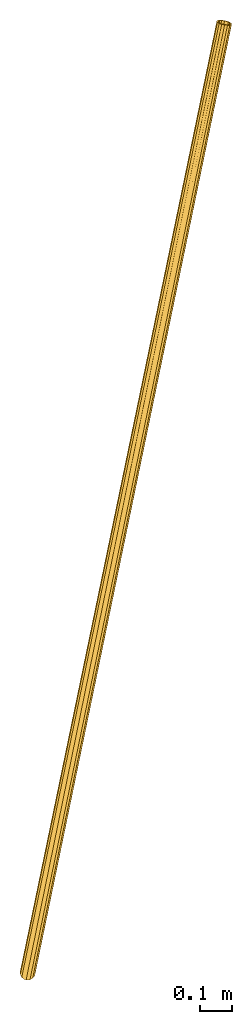
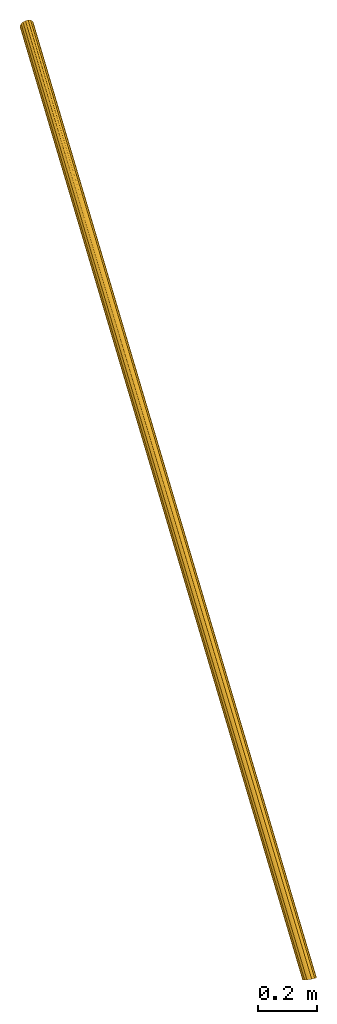
# One storey: 1 railing.
"""IFC4 building model written with IfcOpenShell, lengths in feet."""

from ifc_helpers import new_model, entity, si_unit, converted_unit, derived_unit, direction, frame, origin_with_axes, place, context, subcontext, project, spatial, polygons, material, type_object, element, save


model = new_model("IFC4")

# Units and contexts
model_context = context("Model", 3, precision=1e-05, world=origin_with_axes(), true_north=direction((0.0, 1.0)))
body_context = subcontext(model_context, "Body", "Model", "MODEL_VIEW", scale=1.0)
ifc_project = project(units=[converted_unit("LENGTHUNIT", "foot", entity("IfcReal", 30.48), si_unit("LENGTHUNIT", "METRE", prefix="CENTI"), dimensions=[1, 0, 0, 0, 0, 0, 0]), si_unit("AREAUNIT", "SQUARE_METRE"), si_unit("VOLUMEUNIT", "CUBIC_METRE"), si_unit("ABSORBEDDOSEUNIT", "GRAY"), si_unit("AMOUNTOFSUBSTANCEUNIT", "MOLE"), si_unit("DOSEEQUIVALENTUNIT", "SIEVERT"), si_unit("ELECTRICCAPACITANCEUNIT", "FARAD"), si_unit("ELECTRICCHARGEUNIT", "COULOMB"), si_unit("ELECTRICCONDUCTANCEUNIT", "SIEMENS"), si_unit("ELECTRICCURRENTUNIT", "AMPERE"), si_unit("ELECTRICRESISTANCEUNIT", "OHM"), si_unit("ELECTRICVOLTAGEUNIT", "VOLT"), si_unit("ENERGYUNIT", "JOULE"), si_unit("FORCEUNIT", "NEWTON"), si_unit("FREQUENCYUNIT", "HERTZ"), si_unit("ILLUMINANCEUNIT", "LUX"), si_unit("INDUCTANCEUNIT", "HENRY"), si_unit("LUMINOUSFLUXUNIT", "LUMEN"), si_unit("LUMINOUSINTENSITYUNIT", "CANDELA"), si_unit("MAGNETICFLUXDENSITYUNIT", "TESLA"), si_unit("MAGNETICFLUXUNIT", "WEBER"), si_unit("MASSUNIT", "GRAM"), converted_unit("PLANEANGLEUNIT", "degree", entity("IfcReal", 0.0174532925199433), si_unit("PLANEANGLEUNIT", "RADIAN"), dimensions=[0, 0, 0, 0, 0, 0, 0]), si_unit("POWERUNIT", "WATT"), si_unit("PRESSUREUNIT", "PASCAL"), si_unit("RADIOACTIVITYUNIT", "BECQUEREL"), si_unit("SOLIDANGLEUNIT", "STERADIAN"), si_unit("THERMODYNAMICTEMPERATUREUNIT", "KELVIN"), si_unit("TIMEUNIT", "SECOND"), derived_unit("ACCELERATIONUNIT", [(converted_unit("LENGTHUNIT", "foot", entity("IfcReal", 30.48), si_unit("LENGTHUNIT", "METRE", prefix="CENTI"), dimensions=[1, 0, 0, 0, 0, 0, 0]), 1), (si_unit("TIMEUNIT", "SECOND"), -2)]), derived_unit("ANGULARVELOCITYUNIT", [(converted_unit("PLANEANGLEUNIT", "degree", entity("IfcReal", 0.0174532925199433), si_unit("PLANEANGLEUNIT", "RADIAN"), dimensions=[0, 0, 0, 0, 0, 0, 0]), 1), (si_unit("TIMEUNIT", "SECOND"), -1)]), derived_unit("CURVATUREUNIT", [(converted_unit("PLANEANGLEUNIT", "degree", entity("IfcReal", 0.0174532925199433), si_unit("PLANEANGLEUNIT", "RADIAN"), dimensions=[0, 0, 0, 0, 0, 0, 0]), 1), (converted_unit("LENGTHUNIT", "foot", entity("IfcReal", 30.48), si_unit("LENGTHUNIT", "METRE", prefix="CENTI"), dimensions=[1, 0, 0, 0, 0, 0, 0]), -1)]), derived_unit("DYNAMICVISCOSITYUNIT", [(si_unit("PRESSUREUNIT", "PASCAL"), 1), (si_unit("TIMEUNIT", "SECOND"), 1)]), derived_unit("HEATFLUXDENSITYUNIT", [(si_unit("POWERUNIT", "WATT"), 1), (converted_unit("LENGTHUNIT", "foot", entity("IfcReal", 30.48), si_unit("LENGTHUNIT", "METRE", prefix="CENTI"), dimensions=[1, 0, 0, 0, 0, 0, 0]), -2)]), derived_unit("HEATINGVALUEUNIT", [(si_unit("ENERGYUNIT", "JOULE"), 1), (si_unit("MASSUNIT", "GRAM"), -1)]), derived_unit("INTEGERCOUNTRATEUNIT", [(si_unit("TIMEUNIT", "SECOND"), -1)]), derived_unit("IONCONCENTRATIONUNIT", [(si_unit("MASSUNIT", "GRAM"), 1), (si_unit("VOLUMEUNIT", "CUBIC_METRE"), -1)]), derived_unit("ISOTHERMALMOISTURECAPACITYUNIT", [(si_unit("VOLUMEUNIT", "CUBIC_METRE"), 1), (si_unit("MASSUNIT", "GRAM"), -1)]), derived_unit("KINEMATICVISCOSITYUNIT", [(si_unit("AREAUNIT", "SQUARE_METRE"), 1), (si_unit("TIMEUNIT", "SECOND"), -1)]), derived_unit("LINEARFORCEUNIT", [(si_unit("FORCEUNIT", "NEWTON"), 1), (converted_unit("LENGTHUNIT", "foot", entity("IfcReal", 30.48), si_unit("LENGTHUNIT", "METRE", prefix="CENTI"), dimensions=[1, 0, 0, 0, 0, 0, 0]), -1)]), derived_unit("LINEARMOMENTUNIT", [(si_unit("FORCEUNIT", "NEWTON"), 1), (converted_unit("LENGTHUNIT", "foot", entity("IfcReal", 30.48), si_unit("LENGTHUNIT", "METRE", prefix="CENTI"), dimensions=[1, 0, 0, 0, 0, 0, 0]), -1)]), derived_unit("LINEARSTIFFNESSUNIT", [(si_unit("FORCEUNIT", "NEWTON"), 1), (converted_unit("LENGTHUNIT", "foot", entity("IfcReal", 30.48), si_unit("LENGTHUNIT", "METRE", prefix="CENTI"), dimensions=[1, 0, 0, 0, 0, 0, 0]), -1)]), derived_unit("LINEARVELOCITYUNIT", [(converted_unit("LENGTHUNIT", "foot", entity("IfcReal", 30.48), si_unit("LENGTHUNIT", "METRE", prefix="CENTI"), dimensions=[1, 0, 0, 0, 0, 0, 0]), 1), (si_unit("TIMEUNIT", "SECOND"), -1)]), derived_unit("LUMINOUSINTENSITYDISTRIBUTIONUNIT", [(si_unit("LUMINOUSINTENSITYUNIT", "CANDELA"), 1), (si_unit("LUMINOUSFLUXUNIT", "LUMEN"), -1)]), derived_unit("MASSDENSITYUNIT", [(si_unit("MASSUNIT", "GRAM"), 1), (si_unit("VOLUMEUNIT", "CUBIC_METRE"), -1)]), derived_unit("MASSFLOWRATEUNIT", [(si_unit("MASSUNIT", "GRAM"), 1), (si_unit("TIMEUNIT", "SECOND"), -1)]), derived_unit("MASSPERLENGTHUNIT", [(si_unit("MASSUNIT", "GRAM"), 1), (converted_unit("LENGTHUNIT", "foot", entity("IfcReal", 30.48), si_unit("LENGTHUNIT", "METRE", prefix="CENTI"), dimensions=[1, 0, 0, 0, 0, 0, 0]), -1)]), derived_unit("MODULUSOFELASTICITYUNIT", [(si_unit("FORCEUNIT", "NEWTON"), 1), (si_unit("AREAUNIT", "SQUARE_METRE"), -1)]), derived_unit("MODULUSOFLINEARSUBGRADEREACTIONUNIT", [(si_unit("FORCEUNIT", "NEWTON"), 1), (converted_unit("LENGTHUNIT", "foot", entity("IfcReal", 30.48), si_unit("LENGTHUNIT", "METRE", prefix="CENTI"), dimensions=[1, 0, 0, 0, 0, 0, 0]), -2)]), derived_unit("MODULUSOFROTATIONALSUBGRADEREACTIONUNIT", [(si_unit("FORCEUNIT", "NEWTON"), 1), (converted_unit("LENGTHUNIT", "foot", entity("IfcReal", 30.48), si_unit("LENGTHUNIT", "METRE", prefix="CENTI"), dimensions=[1, 0, 0, 0, 0, 0, 0]), 1)]), derived_unit("MODULUSOFSUBGRADEREACTIONUNIT", [(si_unit("FORCEUNIT", "NEWTON"), 1), (si_unit("VOLUMEUNIT", "CUBIC_METRE"), -1)]), derived_unit("MOISTUREDIFFUSIVITYUNIT", [(si_unit("VOLUMEUNIT", "CUBIC_METRE"), 1), (si_unit("TIMEUNIT", "SECOND"), -1)]), derived_unit("MOLECULARWEIGHTUNIT", [(si_unit("MASSUNIT", "GRAM"), 1), (si_unit("AMOUNTOFSUBSTANCEUNIT", "MOLE"), -1)]), derived_unit("PLANARFORCEUNIT", [(si_unit("FORCEUNIT", "NEWTON"), 1), (converted_unit("LENGTHUNIT", "foot", entity("IfcReal", 30.48), si_unit("LENGTHUNIT", "METRE", prefix="CENTI"), dimensions=[1, 0, 0, 0, 0, 0, 0]), -2)]), derived_unit("ROTATIONALFREQUENCYUNIT", [(si_unit("TIMEUNIT", "SECOND"), -1)]), derived_unit("ROTATIONALMASSUNIT", [(si_unit("MASSUNIT", "GRAM"), 1), (converted_unit("LENGTHUNIT", "foot", entity("IfcReal", 30.48), si_unit("LENGTHUNIT", "METRE", prefix="CENTI"), dimensions=[1, 0, 0, 0, 0, 0, 0]), 2)]), derived_unit("ROTATIONALSTIFFNESSUNIT", [(si_unit("FORCEUNIT", "NEWTON"), 1), (converted_unit("LENGTHUNIT", "foot", entity("IfcReal", 30.48), si_unit("LENGTHUNIT", "METRE", prefix="CENTI"), dimensions=[1, 0, 0, 0, 0, 0, 0]), 1), (converted_unit("PLANEANGLEUNIT", "degree", entity("IfcReal", 0.0174532925199433), si_unit("PLANEANGLEUNIT", "RADIAN"), dimensions=[0, 0, 0, 0, 0, 0, 0]), -1)]), derived_unit("SECTIONAREAINTEGRALUNIT", [(converted_unit("LENGTHUNIT", "foot", entity("IfcReal", 30.48), si_unit("LENGTHUNIT", "METRE", prefix="CENTI"), dimensions=[1, 0, 0, 0, 0, 0, 0]), 5)]), derived_unit("SECTIONMODULUSUNIT", [(converted_unit("LENGTHUNIT", "foot", entity("IfcReal", 30.48), si_unit("LENGTHUNIT", "METRE", prefix="CENTI"), dimensions=[1, 0, 0, 0, 0, 0, 0]), 3)]), derived_unit("SHEARMODULUSUNIT", [(si_unit("FORCEUNIT", "NEWTON"), 1), (si_unit("AREAUNIT", "SQUARE_METRE"), -1)]), derived_unit("SOUNDPOWERUNIT", [(si_unit("ENERGYUNIT", "JOULE"), 1), (si_unit("TIMEUNIT", "SECOND"), -1)]), derived_unit("SPECIFICHEATCAPACITYUNIT", [(si_unit("FORCEUNIT", "NEWTON"), 1), (si_unit("MASSUNIT", "GRAM"), -1), (si_unit("THERMODYNAMICTEMPERATUREUNIT", "KELVIN"), -1)]), derived_unit("TEMPERATUREGRADIENTUNIT", [(si_unit("THERMODYNAMICTEMPERATUREUNIT", "KELVIN"), 1), (converted_unit("LENGTHUNIT", "foot", entity("IfcReal", 30.48), si_unit("LENGTHUNIT", "METRE", prefix="CENTI"), dimensions=[1, 0, 0, 0, 0, 0, 0]), -1)]), derived_unit("THERMALADMITTANCEUNIT", [(si_unit("POWERUNIT", "WATT"), 1), (si_unit("AREAUNIT", "SQUARE_METRE"), -1), (si_unit("THERMODYNAMICTEMPERATUREUNIT", "KELVIN"), -1)]), derived_unit("THERMALCONDUCTANCEUNIT", [(si_unit("POWERUNIT", "WATT"), 1), (converted_unit("LENGTHUNIT", "foot", entity("IfcReal", 30.48), si_unit("LENGTHUNIT", "METRE", prefix="CENTI"), dimensions=[1, 0, 0, 0, 0, 0, 0]), -1), (si_unit("THERMODYNAMICTEMPERATUREUNIT", "KELVIN"), -1)]), derived_unit("THERMALEXPANSIONCOEFFICIENTUNIT", [(si_unit("THERMODYNAMICTEMPERATUREUNIT", "KELVIN"), -1)]), derived_unit("THERMALRESISTANCEUNIT", [(si_unit("AREAUNIT", "SQUARE_METRE"), 1), (si_unit("POWERUNIT", "WATT"), -1)]), derived_unit("THERMALTRANSMITTANCEUNIT", [(si_unit("POWERUNIT", "WATT"), 1), (si_unit("AREAUNIT", "SQUARE_METRE"), -1), (si_unit("THERMODYNAMICTEMPERATUREUNIT", "KELVIN"), -1)]), derived_unit("TORQUEUNIT", [(si_unit("FORCEUNIT", "NEWTON"), 1), (converted_unit("LENGTHUNIT", "foot", entity("IfcReal", 30.48), si_unit("LENGTHUNIT", "METRE", prefix="CENTI"), dimensions=[1, 0, 0, 0, 0, 0, 0]), 1)]), derived_unit("VAPORPERMEABILITYUNIT", [(si_unit("MASSUNIT", "GRAM"), 1), (si_unit("TIMEUNIT", "SECOND"), -1)]), derived_unit("VOLUMETRICFLOWRATEUNIT", [(si_unit("VOLUMEUNIT", "CUBIC_METRE"), 1), (si_unit("TIMEUNIT", "SECOND"), -1)]), derived_unit("WARPINGCONSTANTUNIT", [(converted_unit("LENGTHUNIT", "foot", entity("IfcReal", 30.48), si_unit("LENGTHUNIT", "METRE", prefix="CENTI"), dimensions=[1, 0, 0, 0, 0, 0, 0]), 6)]), derived_unit("WARPINGMOMENTUNIT", [(si_unit("FORCEUNIT", "NEWTON"), 1), (converted_unit("LENGTHUNIT", "foot", entity("IfcReal", 30.48), si_unit("LENGTHUNIT", "METRE", prefix="CENTI"), dimensions=[1, 0, 0, 0, 0, 0, 0]), 2)])], contexts=[model_context])

# Site, building, storey
site_placement = place(None, origin_with_axes())
site = spatial("IfcSite", under=ifc_project, at=site_placement, CompositionType="ELEMENT")
building_placement = place(site_placement, origin_with_axes())
building = spatial("IfcBuilding", under=site, at=building_placement, Name="Bldg 1", CompositionType="ELEMENT")
storey_placement = place(building_placement, origin_with_axes())
storey = spatial("IfcBuildingStorey", under=building, at=storey_placement, Name="Floor 1", CompositionType="ELEMENT", Elevation=0.0)

# Railing
ifc_material = material(Name="Plastic - lt gray")
railing_type = type_object("IfcRailingType", Name="Pipe Railing", PredefinedType="HANDRAIL")
railing_placement = place(storey_placement, frame((84.4046960800525, -39.4958102454068, 0.571428571427165), z_axis=(0.0, 0.0, 1.0), x_axis=(1.0, 0.0, 0.0)))
element("IfcRailing", 1, at=railing_placement, inside=storey, type_object=railing_type, material=ifc_material, Name="Pipe Railing", ObjectType="Railing", PredefinedType="HANDRAIL", context=body_context, shape_type="Tessellation", body=[
    polygons([(0.0530947558472495, 0.147484624726583, 3.41424963247349), (0.0235016216516423, 0.156338738114096, 3.41277213514505), (2.03558772980999, 9.83722766018549, 9.62738095254443), (-3.0555202579248e-15, 3.819400322406e-15, 3.49999999999999), (0.00850381686177685, 0.000401182081250155, 3.49883074280154), (2.00487640463021, 9.79791371268742, 9.7825647477446), (0.0393109354324591, 0.00185456050487615, 3.49459482783091), (2.03485521016422, 9.79092340340049, 9.78523859800831), (-0.0210110122511663, 0.00756400585996037, 3.49825965060244), (-0.00722719183637572, 0.153194070081667, 3.41791445524502), (1.99768770723987, 9.842191509338, 9.63716277803514), (-0.00232844159755159, 0.137263595389374, 3.42598607341195), (0.0219311479982512, 0.139746228046558, 3.42192634701723), (2.00469339312021, 9.83644305985017, 9.65177011298523), (-0.013210405082911, 0.0222924920564462, 3.48941649079939), (2.01036868053362, 9.80148690459973, 9.7665611417032), (0.00337723616800102, 0.0163209084827926, 3.4907904508501), (0.0100907757957285, 0.0166376311785136, 3.48986735306185), (2.03403615858679, 9.79596823937319, 9.76867207612194), (0.034412185193634, 0.0177850351971689, 3.48652320966397), (-0.0449631807355127, 0.0270689421669121, 3.49038727142029), (-0.0596278829838043, 0.0542552516532599, 3.47731850875161), (-0.0627725510145943, 0.0849840651442091, 3.46104296324408), (-0.0539184376266828, 0.114577199343155, 3.44403843916304), (-0.0344135013206412, 0.138529367830736, 3.42889372115344), (0.0770469243315952, 0.127979688419628, 3.42212201165565), (0.0917116265798871, 0.100793378933283, 3.43519077432433), (0.0948562946106773, 0.0700645654423328, 3.45146631983185), (0.0860021812227658, 0.0404714312433865, 3.46847084391289), (0.0664972449167248, 0.016519262755805, 3.48361556192249), (0.0558750611022653, 0.0293624317110585, 3.47785536815733), (0.0712736950280873, 0.0482720384117826, 3.46589901183396), (0.0782637845448592, 0.0716350390951617, 3.45247438755945), (0.0757811518889718, 0.0958946286932786, 3.43962527268509), (0.064203755377163, 0.117357504603552, 3.42930782847298), (0.0452941486789939, 0.132756138530094, 3.42309279227654), (-0.0237913175061815, 0.125686198875479, 3.4346539149186), (-0.0391899514320037, 0.106776592174758, 3.44661027124198), (-0.0461800409487764, 0.0834135914913779, 3.46003489551648), (-0.043697408292889, 0.0591540018932595, 3.47288401039084), (-0.0321200117810802, 0.0376911259829855, 3.48320145460296), (2.05156074980926, 9.82828584394195, 9.64653409639279), (2.02739015856075, 9.83830131408696, 9.62949670884139), (2.05705302571267, 9.83185903585424, 9.63053049035141), (2.08306012245791, 9.82228479269878, 9.64477725936221), (2.10113616568982, 9.8115842074045, 9.66842800568547), (2.10852924168609, 9.8013863470814, 9.69788211758802), (2.10411382164469, 9.79324374351984, 9.72865547353488), (2.08856211324104, 9.78839603429918, 9.75606310904431), (2.064241723103, 9.78758123920368, 9.77593246006084), (1.97886930788497, 9.80748795584289, 9.76831797873377), (1.96079326465306, 9.81818854113718, 9.74466723241051), (1.95340018865679, 9.82838640146028, 9.71521312050797), (1.95781560869819, 9.83652900502184, 9.68443976456111), (1.97336731710184, 9.84137671424249, 9.65703212905167), (2.02814269679458, 9.83337185307303, 9.64571795309542), (2.0346144635703, 9.83252423157188, 9.64404761917677), (1.98549308511649, 9.83579980056425, 9.66745644273511), (1.97321542058729, 9.83197266170584, 9.68909404971624), (1.96972956265987, 9.82554429047303, 9.71338880441113), (1.9755662016043, 9.81749334811268, 9.73664205064998), (1.98983676205054, 9.8090455176172, 9.75531369248413), (2.05723603722267, 9.7933296886915, 9.76132512511077), (2.07643634522638, 9.79397294797743, 9.74563879536088), (2.08871400975558, 9.79780008683584, 9.72400118837975), (2.092199867683, 9.80422845806865, 9.69970643368486), (2.08636322873858, 9.81227940042899, 9.676453187446), (2.07209266829233, 9.82072723092448, 9.65778154561185)], [[[1, 2, 3]], [[4, 5, 6]], [[5, 7, 8]], [[9, 4, 6]], [[10, 11, 2]], [[12, 13, 14]], [[15, 16, 17]], [[17, 16, 18]], [[18, 19, 20]], [[21, 22, 23, 24, 25, 10, 2, 1, 26, 27, 28, 29, 30, 7, 5, 4, 9], [20, 31, 32, 33, 34, 35, 36, 13, 12, 37, 38, 39, 40, 41, 15, 17, 18]], [[36, 42, 13]], [[43, 2, 11]], [[43, 3, 2]], [[44, 1, 3]], [[44, 45, 26, 1]], [[45, 46, 27, 26]], [[46, 47, 28, 27]], [[47, 48, 29, 28]], [[48, 49, 30, 29]], [[49, 50, 7, 30]], [[50, 8, 7]], [[8, 6, 5]], [[6, 51, 21, 9]], [[51, 52, 22, 21]], [[52, 53, 23, 22]], [[53, 54, 24, 23]], [[54, 55, 25, 24]], [[55, 11, 10, 25]], [[56, 13, 57]], [[56, 14, 13]], [[14, 58, 37, 12]], [[58, 59, 38, 37]], [[59, 60, 39, 38]], [[60, 61, 40, 39]], [[61, 62, 41, 40]], [[62, 16, 15, 41]], [[19, 18, 16]], [[63, 20, 19]], [[63, 64, 31, 20]], [[64, 65, 32, 31]], [[65, 66, 33, 32]], [[66, 67, 34, 33]], [[67, 68, 35, 34]], [[68, 42, 36, 35]], [[57, 13, 42]], [[55, 54, 53, 52, 51, 6, 8, 50, 49, 48, 47, 46, 45, 44, 3, 43, 11], [42, 68, 67, 66, 65, 64, 63, 19, 16, 62, 61, 60, 59, 58, 14, 56, 57]]], closed=True),
])

save(model, "model.ifc")
